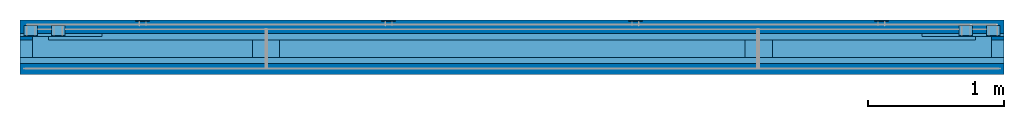
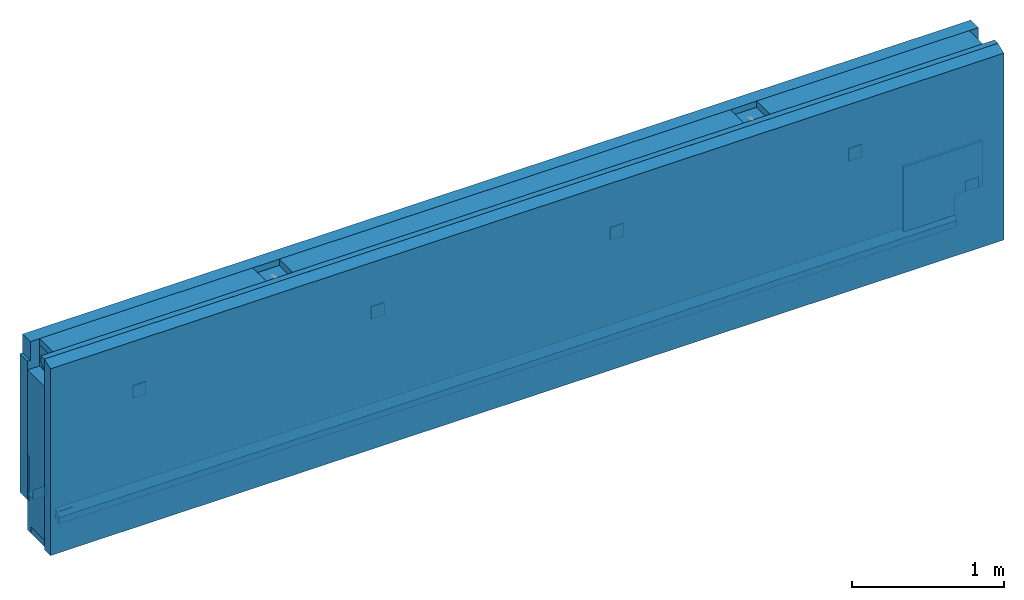
# One storey, part 1 of 10: 8 plates, 4 beams, 3 walls, 2 slabs, 12 elements without a shape of their own.
"""IFC2X3 building model written with IfcOpenShell, lengths in millimetres."""

from ifc_helpers import new_model, si_unit, frame, frame_2d, origin_with_axes, origin_2d_with_axis, place, context, subcontext, project, spatial, polyline, rectangle, outline, extrude, boolean, material, type_object, element, aggregate, save


model = new_model("IFC2X3")

# Units and contexts
model_context = context("Model", 3, precision=1e-05, world=origin_with_axes())
body_context = subcontext(model_context, "Body", "Model", "MODEL_VIEW")
ifc_project = project(units=[si_unit("LENGTHUNIT", "METRE", prefix="MILLI"), si_unit("AREAUNIT", "SQUARE_METRE"), si_unit("VOLUMEUNIT", "CUBIC_METRE"), si_unit("MASSUNIT", "GRAM", prefix="KILO"), si_unit("TIMEUNIT", "SECOND"), si_unit("PLANEANGLEUNIT", "RADIAN"), si_unit("SOLIDANGLEUNIT", "STERADIAN"), si_unit("THERMODYNAMICTEMPERATUREUNIT", "DEGREE_CELSIUS"), si_unit("LUMINOUSINTENSITYUNIT", "LUMEN")], contexts=[model_context])

# Site, building, storey
site_placement = place(None, origin_with_axes())
site = spatial("IfcSite", under=ifc_project, at=site_placement, CompositionType="ELEMENT")
building_placement = place(site_placement, origin_with_axes())
building = spatial("IfcBuilding", under=site, at=building_placement, Name="Undefined", CompositionType="ELEMENT")
storey_placement = place(building_placement, origin_with_axes())
storey = spatial("IfcBuildingStorey", under=building, at=storey_placement, Name="Undefined", CompositionType="ELEMENT", Elevation=0.0)

# Assembly, beams
assembly_1_placement = place(storey_placement, origin_with_axes())
assembly_1 = element("IfcElementAssembly", 1, at=assembly_1_placement, inside=storey, AssemblyPlace="NOTDEFINED", PredefinedType="REINFORCEMENT_UNIT")
ifc_material_1 = material(Name="CONCRETE/C30/37")
beam_type_1 = type_object("IfcBeamType", Name="600X600", PredefinedType="NOTDEFINED")
beam_1_placement = place(assembly_1_placement, frame((14999.9998000424, -202.500205694594, 672.500000000001), z_axis=(0.0, 0.0, 1.0), x_axis=(-7.84935082265784e-18, -1.0, -8.08224170819634e-13)))
beam_1 = element("IfcBeam", 2, at=beam_1_placement, type_object=beam_type_1, material=ifc_material_1, ObjectType="600X600", context=body_context, shape_type="CSG", body=[
    boolean("DIFFERENCE", extrude(rectangle(XDim=600.0, YDim=600.0, at=origin_2d_with_axis()), frame((20.0, 0.0, 0.0), z_axis=(-1.0, -1.7999998817686e-08, 3.23999979946689e-16), x_axis=(-7.84935082265784e-18, -1.0, -8.08224170819634e-13)), (0.0, 0.0, 1.0), 20.0), extrude(rectangle(XDim=210.0, YDim=240.0, at=origin_2d_with_axis()), frame((299.999999999992, -194.999999999993, -179.999999999999), z_axis=(-1.0, -1.7999998817686e-08, 3.23999979946689e-16), x_axis=(-7.84935082265784e-18, -1.0, -8.08224170819634e-13)), (0.0, 0.0, 1.0), 500.0)),
])
beam_2_placement = place(assembly_1_placement, frame((21619.9998000424, -202.500205694595, 672.5), z_axis=(0.0, 0.0, 1.0), x_axis=(-7.84935082265784e-18, -1.0, -8.08224170819634e-13)))
beam_2 = element("IfcBeam", 3, at=beam_2_placement, type_object=beam_type_1, material=ifc_material_1, ObjectType="600X600", context=body_context, shape_type="CSG", body=[
    boolean("DIFFERENCE", extrude(rectangle(XDim=600.0, YDim=600.0, at=origin_2d_with_axis()), frame((20.0, 0.0, 0.0), z_axis=(-1.0, -1.7999998817686e-08, 3.23999979946689e-16), x_axis=(-7.84935082265784e-18, -1.0, -8.08224170819634e-13)), (0.0, 0.0, 1.0), 20.0), extrude(rectangle(XDim=210.0, YDim=240.0, at=origin_2d_with_axis()), frame((299.999999999991, 195.0, -179.999999999999), z_axis=(-1.0, -1.7999998817686e-08, 3.23999979946689e-16), x_axis=(-7.84935082265784e-18, -1.0, -8.08224170819634e-13)), (0.0, 0.0, 1.0), 500.0)),
])

# Assembly, beam
assembly_2_placement = place(storey_placement, origin_with_axes())
assembly_2 = element("IfcElementAssembly", 4, at=assembly_2_placement, inside=storey, AssemblyPlace="NOTDEFINED", PredefinedType="NOTDEFINED")
ifc_material_2 = material(Name="TIMBER/C24")
beam_type_2 = type_object("IfcBeamType", Name="50X175", PredefinedType="NOTDEFINED")
beam_3_placement = place(assembly_2_placement, frame((21919.9998033964, -335.000205699542, 397.499999999999), z_axis=(0.0, 0.0, 1.0), x_axis=(-1.0, -1.7999998817686e-08, 3.23999979946689e-16)))
beam_3 = element("IfcBeam", 5, at=beam_3_placement, type_object=beam_type_2, material=ifc_material_2, ObjectType="50X175", context=body_context, shape_type="SweptSolid", body=[
    extrude(rectangle(XDim=175.0, YDim=50.0, at=origin_2d_with_axis()), frame((7219.99979645404, 5.97224385426358e-21, 0.0), z_axis=(-1.0, -1.7999998817686e-08, 3.23999979946689e-16), x_axis=(-7.84935082265784e-18, -1.0, -8.08224170819634e-13)), (0.0, 0.0, 1.0), 7220.0),
])
aggregate(assembly_2, [beam_3])

assembly_3_placement = place(storey_placement, origin_with_axes())
assembly_3 = element("IfcElementAssembly", 6, at=assembly_3_placement, inside=storey, AssemblyPlace="NOTDEFINED", PredefinedType="NOTDEFINED")
beam_4_placement = place(assembly_3_placement, frame((21919.9998007894, -290.000205686386, 1847.5), z_axis=(0.0, 0.0, 1.0), x_axis=(-1.0, -1.7999998817686e-08, 3.23999979946689e-16)))
beam_4 = element("IfcBeam", 7, at=beam_4_placement, type_object=beam_type_2, material=ifc_material_2, ObjectType="50X175", context=body_context, shape_type="CSG", body=[
    boolean("DIFFERENCE", boolean("DIFFERENCE", boolean("DIFFERENCE", boolean("DIFFERENCE", extrude(rectangle(XDim=175.0, YDim=50.0, at=origin_2d_with_axis()), frame((7219.99979645404, 5.97224385426358e-21, 0.0), z_axis=(-1.0, -1.7999998817686e-08, 3.23999979946689e-16), x_axis=(-7.84935082265784e-18, -1.0, -8.08224170819634e-13)), (0.0, 0.0, 1.0), 7220.0), extrude(rectangle(XDim=200.0, YDim=50.0, at=origin_2d_with_axis()), frame((5414.63995375537, 132.499974342812, -4.54747350886464e-13), z_axis=(-7.84935082265784e-18, -1.0, -8.08224170819634e-13), x_axis=(-1.0, -1.7999998817686e-08, 3.23999979946689e-16)), (0.0, 0.0, 1.0), 320.0)), extrude(rectangle(XDim=200.0, YDim=50.0, at=origin_2d_with_axis()), frame((1799.37995375537, 132.499999649632, -4.54747350886464e-13), z_axis=(-7.84935082265784e-18, -1.0, -8.08224170819634e-13), x_axis=(-1.0, -1.7999998817686e-08, 3.23999979946689e-16)), (0.0, 0.0, 1.0), 320.0)), extrude(rectangle(XDim=90.0, YDim=220.0, at=origin_2d_with_axis()), frame((7175.00000188457, 162.49994852021, -84.9999999999991), z_axis=(-7.84935082265784e-18, -1.0, -8.08224170819634e-13), x_axis=(1.0, 0.0, 0.0)), (0.0, 0.0, 1.0), 300.0)), extrude(rectangle(XDim=90.0, YDim=220.0, at=origin_2d_with_axis()), frame((45.0000018845698, 162.49999843021, -84.9999999999991), z_axis=(-7.84935082265784e-18, -1.0, -8.08224170819634e-13), x_axis=(1.0, 0.0, 0.0)), (0.0, 0.0, 1.0), 300.0)),
])
aggregate(assembly_3, [beam_4])

# Assembly, plate
assembly_4_placement = place(storey_placement, origin_with_axes())
assembly_4 = element("IfcElementAssembly", 8, at=assembly_4_placement, inside=storey, Name="Steel Assembly", AssemblyPlace="NOTDEFINED", PredefinedType="RIGID_FRAME")
ifc_material_3 = material(Name="STEEL/Steel_Undefined")
plate_type_1 = type_object("IfcPlateType", Name="PL100X10", PredefinedType="NOTDEFINED")
plate_1_placement = place(assembly_4_placement, frame((17404.9998002224, -112.500206835272, 1072.49943678625), z_axis=(-1.0, -1.7999998817686e-08, 3.23999979946689e-16), x_axis=(0.0, 0.0, 1.0)))
plate_1 = element("IfcPlate", 9, at=plate_1_placement, type_object=plate_type_1, material=ifc_material_3, Name="RT38", ObjectType="PL100X10", context=body_context, shape_type="SweptSolid", body=[
    extrude(outline(polyline([(0.0, 0.0), (100.0, -2.1316282072803e-11), (99.9999999999984, 9.99999999997873), (-1.59161572810262e-12, 10.0), (0.0, 0.0)])), frame((0.0, 1.26163860546922e-22, -50.0), z_axis=(0.0, 0.0, 1.0), x_axis=(1.0, 0.0, 0.0)), (0.0, 0.0, 1.0), 100.0),
])
aggregate(assembly_4, [plate_1])

assembly_5_placement = place(storey_placement, origin_with_axes())
assembly_5 = element("IfcElementAssembly", 10, at=assembly_5_placement, inside=storey, Name="Steel Assembly", AssemblyPlace="NOTDEFINED", PredefinedType="RIGID_FRAME")
plate_2_placement = place(assembly_5_placement, frame((19214.9998002224, -112.500206835272, 1072.49943678625), z_axis=(-1.0, -1.7999998817686e-08, 3.23999979946689e-16), x_axis=(0.0, 0.0, 1.0)))
plate_2 = element("IfcPlate", 11, at=plate_2_placement, type_object=plate_type_1, material=ifc_material_3, Name="RT38", ObjectType="PL100X10", context=body_context, shape_type="SweptSolid", body=[
    extrude(outline(polyline([(0.0, 0.0), (100.0, -2.1316282072803e-11), (99.9999999999984, 9.99999999997873), (-1.59161572810262e-12, 10.0), (0.0, 0.0)])), frame((0.0, 1.26163860546922e-22, -50.0), z_axis=(0.0, 0.0, 1.0), x_axis=(1.0, 0.0, 0.0)), (0.0, 0.0, 1.0), 100.0),
])
aggregate(assembly_5, [plate_2])

assembly_6_placement = place(storey_placement, origin_with_axes())
assembly_6 = element("IfcElementAssembly", 12, at=assembly_6_placement, inside=storey, Name="Steel Assembly", AssemblyPlace="NOTDEFINED", PredefinedType="RIGID_FRAME")
plate_3_placement = place(assembly_6_placement, frame((21019.9998002224, -112.500206835272, 1072.49943678625), z_axis=(-1.0, -1.7999998817686e-08, 3.23999979946689e-16), x_axis=(0.0, 0.0, 1.0)))
plate_3 = element("IfcPlate", 13, at=plate_3_placement, type_object=plate_type_1, material=ifc_material_3, Name="RT38", ObjectType="PL100X10", context=body_context, shape_type="SweptSolid", body=[
    extrude(outline(polyline([(0.0, 0.0), (100.0, -2.1316282072803e-11), (99.9999999999984, 9.99999999997873), (-1.59161572810262e-12, 10.0), (0.0, 0.0)])), frame((0.0, 1.26163860546922e-22, -50.0), z_axis=(0.0, 0.0, 1.0), x_axis=(1.0, 0.0, 0.0)), (0.0, 0.0, 1.0), 100.0),
])
aggregate(assembly_6, [plate_3])

assembly_7_placement = place(storey_placement, origin_with_axes())
assembly_7 = element("IfcElementAssembly", 14, at=assembly_7_placement, inside=storey, Name="Steel Assembly", AssemblyPlace="NOTDEFINED", PredefinedType="RIGID_FRAME")
plate_4_placement = place(assembly_7_placement, frame((15599.9998002224, -112.500206835272, 1072.49943678625), z_axis=(-1.0, -1.7999998817686e-08, 3.23999979946689e-16), x_axis=(0.0, 0.0, 1.0)))
plate_4 = element("IfcPlate", 15, at=plate_4_placement, type_object=plate_type_1, material=ifc_material_3, Name="RT38", ObjectType="PL100X10", context=body_context, shape_type="SweptSolid", body=[
    extrude(outline(polyline([(0.0, 0.0), (100.0, -2.1316282072803e-11), (99.9999999999984, 9.99999999997873), (-1.59161572810262e-12, 10.0), (0.0, 0.0)])), frame((0.0, 1.26163860546922e-22, -50.0), z_axis=(0.0, 0.0, 1.0), x_axis=(1.0, 0.0, 0.0)), (0.0, 0.0, 1.0), 100.0),
])
aggregate(assembly_7, [plate_4])

assembly_8_placement = place(storey_placement, origin_with_axes())
assembly_8 = element("IfcElementAssembly", 16, at=assembly_8_placement, inside=storey, Name="Steel Assembly", AssemblyPlace="NOTDEFINED", PredefinedType="RIGID_FRAME")
plate_type_2 = type_object("IfcPlateType", Name="PL100X80", PredefinedType="NOTDEFINED")
plate_5_placement = place(assembly_8_placement, frame((14780.0001999576, -222.499790525409, 612.499999999998), z_axis=(1.0, 0.0, 0.0), x_axis=(0.0, 1.0, 0.0)))
plate_5 = element("IfcPlate", 17, at=plate_5_placement, type_object=plate_type_2, material=ifc_material_3, Name="RT24", ObjectType="PL100X80", context=body_context, shape_type="SweptSolid", body=[
    extrude(outline(polyline([(-0.000418949182403594, 0.0), (79.9995810508176, 0.0), (79.9995810508176, 6.0), (5.9995810508176, 6.0), (5.9995810508176, 80.0), (-0.000418949182403594, 80.0), (-0.000418949182403594, 0.0)])), frame((0.0, 1.26163860546922e-22, -50.0), z_axis=(0.0, 0.0, 1.0), x_axis=(1.0, 0.0, 0.0)), (0.0, 0.0, 1.0), 100.0),
])
aggregate(assembly_8, [plate_5])

assembly_9_placement = place(storey_placement, origin_with_axes())
assembly_9 = element("IfcElementAssembly", 18, at=assembly_9_placement, inside=storey, Name="Steel Assembly", AssemblyPlace="NOTDEFINED", PredefinedType="RIGID_FRAME")
plate_6_placement = place(assembly_9_placement, frame((14980.0001999576, -222.499790525409, 372.499999999998), z_axis=(1.0, 0.0, 0.0), x_axis=(0.0, 1.0, 0.0)))
plate_6 = element("IfcPlate", 19, at=plate_6_placement, type_object=plate_type_2, material=ifc_material_3, Name="RT24", ObjectType="PL100X80", context=body_context, shape_type="SweptSolid", body=[
    extrude(outline(polyline([(-0.000418949182403594, 0.0), (79.9995810508176, 0.0), (79.9995810508176, 6.0), (5.9995810508176, 6.0), (5.9995810508176, 80.0), (-0.000418949182403594, 80.0), (-0.000418949182403594, 0.0)])), frame((0.0, 1.26163860546922e-22, -50.0), z_axis=(0.0, 0.0, 1.0), x_axis=(1.0, 0.0, 0.0)), (0.0, 0.0, 1.0), 100.0),
])
aggregate(assembly_9, [plate_6])

assembly_10_placement = place(storey_placement, origin_with_axes())
assembly_10 = element("IfcElementAssembly", 20, at=assembly_10_placement, inside=storey, Name="Steel Assembly", AssemblyPlace="NOTDEFINED", PredefinedType="RIGID_FRAME")
plate_7_placement = place(assembly_10_placement, frame((21640.0001999576, -222.499790525409, 372.499999999998), z_axis=(1.0, 0.0, 0.0), x_axis=(0.0, 1.0, 0.0)))
plate_7 = element("IfcPlate", 21, at=plate_7_placement, type_object=plate_type_2, material=ifc_material_3, Name="RT24", ObjectType="PL100X80", context=body_context, shape_type="SweptSolid", body=[
    extrude(outline(polyline([(-0.000418949182403594, 0.0), (79.9995810508176, 0.0), (79.9995810508176, 6.0), (5.9995810508176, 6.0), (5.9995810508176, 80.0), (-0.000418949182403594, 80.0), (-0.000418949182403594, 0.0)])), frame((0.0, 1.26163860546922e-22, -50.0), z_axis=(0.0, 0.0, 1.0), x_axis=(1.0, 0.0, 0.0)), (0.0, 0.0, 1.0), 100.0),
])
aggregate(assembly_10, [plate_7])

assembly_11_placement = place(storey_placement, origin_with_axes())
assembly_11 = element("IfcElementAssembly", 22, at=assembly_11_placement, inside=storey, Name="Steel Assembly", AssemblyPlace="NOTDEFINED", PredefinedType="RIGID_FRAME")
plate_8_placement = place(assembly_11_placement, frame((21840.0001999576, -222.499790525409, 612.499999999998), z_axis=(1.0, 0.0, 0.0), x_axis=(0.0, 1.0, 0.0)))
plate_8 = element("IfcPlate", 23, at=plate_8_placement, type_object=plate_type_2, material=ifc_material_3, Name="RT24", ObjectType="PL100X80", context=body_context, shape_type="SweptSolid", body=[
    extrude(outline(polyline([(-0.000418949182403594, 0.0), (79.9995810508176, 0.0), (79.9995810508176, 6.0), (5.9995810508176, 6.0), (5.9995810508176, 80.0), (-0.000418949182403594, 80.0), (-0.000418949182403594, 0.0)])), frame((0.0, 1.26163860546922e-22, -50.0), z_axis=(0.0, 0.0, 1.0), x_axis=(1.0, 0.0, 0.0)), (0.0, 0.0, 1.0), 100.0),
])
aggregate(assembly_11, [plate_8])

# Slab
ifc_material_4 = material(Name="CONCRETE/C30/37")
slab_type_1 = type_object("IfcSlabType", Name="7220X45", PredefinedType="NOTDEFINED")
slab_1_placement = place(assembly_1_placement, frame((18309.9998013828, -377.500230801622, 1872.5), z_axis=(1.0, 0.0, 0.0), x_axis=(-7.84935082265784e-18, -1.0, -8.08224170819634e-13)))
slab_1 = element("IfcSlab", 24, at=slab_1_placement, type_object=slab_type_1, material=ifc_material_4, ObjectType="7220X45", PredefinedType="FLOOR", context=body_context, shape_type="SweptSolid", body=[
    extrude(outline(polyline([(0.0, 0.0), (45.0000001549068, 0.0), (45.0000001549068, 100.0), (1.54906786065112e-07, 50.0), (0.0, 0.0)])), frame((0.0, 0.0, -3610.0), z_axis=(0.0, 0.0, 1.0), x_axis=(1.0, 0.0, 0.0)), (0.0, 0.0, 1.0), 7220.0),
])

slab_type_2 = type_object("IfcSlabType", Name="6800X45", PredefinedType="NOTDEFINED")
slab_2_placement = place(assembly_1_placement, frame((18309.999802788, -247.500135934181, 372.499999999999), z_axis=(1.0, 0.0, 0.0), x_axis=(0.0, 1.0, 0.0)))
slab_2 = element("IfcSlab", 25, at=slab_2_placement, type_object=slab_type_2, material=ifc_material_1, ObjectType="6800X45", PredefinedType="FLOOR", context=body_context, shape_type="SweptSolid", body=[
    extrude(outline(polyline([(0.0, 0.0), (45.0000001549068, 0.0), (45.0000001549068, 100.0), (1.54906786065112e-07, 50.0), (0.0, 0.0)])), frame((0.0, -5.6843418860808e-14, -3400.0), z_axis=(0.0, 0.0, 1.0), x_axis=(1.0, 0.0, 0.0)), (0.0, 0.0, 1.0), 6800.0),
])

# Assembly, wall
assembly_12_placement = place(storey_placement, origin_with_axes())
assembly_12 = element("IfcElementAssembly", 26, at=assembly_12_placement, inside=storey, Name="Steel Assembly", AssemblyPlace="NOTDEFINED", PredefinedType="NOTDEFINED")
ifc_material_5 = material(Name="COS5ggt")
wall_type_1 = type_object("IfcWallType", Name="1500X220", PredefinedType="NOTDEFINED")
wall_1_placement = place(assembly_12_placement, frame((21919.9998011901, -312.500205694594, 397.5), z_axis=(0.0, 0.0, 1.0), x_axis=(-1.0, -1.7999998817686e-08, 3.23999979946689e-16)))
wall_1 = element("IfcWall", 27, at=wall_1_placement, type_object=wall_type_1, material=ifc_material_5, ObjectType="1500X220", context=body_context, shape_type="CSG", body=[
    boolean("DIFFERENCE", boolean("DIFFERENCE", boolean("DIFFERENCE", boolean("DIFFERENCE", boolean("DIFFERENCE", boolean("DIFFERENCE", extrude(rectangle(XDim=7219.99979729039, YDim=220.0, at=frame_2d((0.0, 3609.9998986452), x_axis=(0.0, -1.0))), frame((0.0, 0.0, -25.0), z_axis=(0.0, 0.0, 1.0), x_axis=(-7.84935082265784e-18, -1.0, -8.08224170819634e-13)), (0.0, 0.0, 1.0), 1500.0), extrude(rectangle(XDim=90.0, YDim=220.0, at=origin_2d_with_axis()), frame((7175.00000212772, 139.999948512001, 1365.0), z_axis=(-7.84935082265784e-18, -1.0, -8.08224170819634e-13), x_axis=(1.0, 0.0, 0.0)), (0.0, 0.0, 1.0), 300.0)), extrude(rectangle(XDim=90.0, YDim=220.0, at=origin_2d_with_axis()), frame((45.000002127725, 139.999998422002, 1365.0), z_axis=(-7.84935082265784e-18, -1.0, -8.08224170819634e-13), x_axis=(1.0, 0.0, 0.0)), (0.0, 0.0, 1.0), 300.0)), extrude(outline(polyline([(0.0, 0.0), (45.0000001549068, 0.0), (45.0000001549068, 100.0), (1.54906786065112e-07, 50.0), (0.0, 0.0)])), frame((7009.99999794708, -65.0000474303088, -25.0000000000009), z_axis=(-1.0, -1.7999998817686e-08, 3.23999979946689e-16), x_axis=(-7.84935082265784e-18, -1.0, -8.08224170819634e-13)), (0.0, 0.0, 1.0), 6800.0)), extrude(rectangle(XDim=175.0, YDim=50.0, at=origin_2d_with_axis()), frame((7219.9997944052, 22.5000000049478, -9.09494701772928e-13), z_axis=(-1.0, -1.7999998817686e-08, 3.23999979946689e-16), x_axis=(-7.84935082265784e-18, -1.0, -8.08224170819634e-13)), (0.0, 0.0, 1.0), 7220.0)), extrude(rectangle(XDim=175.0, YDim=50.0, at=origin_2d_with_axis()), frame((7219.99979655595, -22.500001262988, 1450.0), z_axis=(-1.0, -1.7999998817686e-08, 3.23999979946689e-16), x_axis=(-7.84935082265784e-18, -1.0, -8.08224170819634e-13)), (0.0, 0.0, 1.0), 7220.0)), extrude(outline(polyline([(0.0, 0.0), (45.0000001549068, 0.0), (45.0000001549068, 100.0), (1.54906786065112e-07, 50.0), (0.0, 0.0)])), frame((7219.99999655965, 65.0000781577995, 1475.0), z_axis=(-1.0, -1.7999998817686e-08, 3.23999979946689e-16), x_axis=(0.0, 1.0, 0.0)), (0.0, 0.0, 1.0), 7220.0)),
])
aggregate(assembly_12, [wall_1])

# Wall
wall_type_2 = type_object("IfcWallType", Name="1525X80", PredefinedType="NOTDEFINED")
wall_2_placement = place(assembly_1_placement, frame((21919.9998019722, -462.500205694594, 347.5), z_axis=(0.0, 0.0, 1.0), x_axis=(-1.0, -1.7999998817686e-08, 3.23999979946689e-16)))
wall_2 = element("IfcWall", 28, at=wall_2_placement, type_object=wall_type_2, material=ifc_material_4, ObjectType="1525X80", context=body_context, shape_type="CSG", body=[
    boolean("DIFFERENCE", extrude(rectangle(XDim=7219.99979483744, YDim=80.0, at=frame_2d((0.0, 3609.9998986452), x_axis=(0.0, -1.0))), frame((0.0, 0.0, 0.0), z_axis=(0.0, 0.0, 1.0), x_axis=(-7.84935082265784e-18, -1.0, -8.08224170819634e-13)), (0.0, 0.0, 1.0), 1525.0), extrude(outline(polyline([(0.0, 0.0), (79.999999842608, 0.0), (-1.57392037181125e-07, 30.0), (0.0, 0.0)])), frame((-3.63797880709171e-12, 40.0000001487744, 1525.0), z_axis=(1.0, 0.0, 0.0), x_axis=(-7.84935082265784e-18, -1.0, -8.08224170819634e-13)), (0.0, 0.0, 1.0), 7220.0)),
])

wall_type_3 = type_object("IfcWallType", Name="1500X100", PredefinedType="NOTDEFINED")
wall_3_placement = place(assembly_1_placement, frame((21919.9998002971, -152.500205694594, 372.5), z_axis=(0.0, 0.0, 1.0), x_axis=(-1.0, -1.7999998817686e-08, 3.23999979946689e-16)))
wall_3 = element("IfcWall", 29, at=wall_3_placement, type_object=wall_type_3, material=ifc_material_1, ObjectType="1500X100", context=body_context, shape_type="CSG", body=[
    boolean("DIFFERENCE", boolean("DIFFERENCE", boolean("DIFFERENCE", boolean("DIFFERENCE", extrude(rectangle(XDim=7219.99979935469, YDim=100.0, at=frame_2d((0.0, 3609.9998986452), x_axis=(0.0, -1.0))), frame((0.0, 0.0, 0.0), z_axis=(0.0, 0.0, 1.0), x_axis=(-7.84935082265784e-18, -1.0, -8.08224170819634e-13)), (0.0, 0.0, 1.0), 1500.0), extrude(rectangle(XDim=20.0, YDim=150.0, at=origin_2d_with_axis()), frame((7210.00000130474, 149.999948267002, 1425.0), z_axis=(-7.84935082265784e-18, -1.0, -8.08224170819634e-13), x_axis=(1.0, 0.0, 0.0)), (0.0, 0.0, 1.0), 300.0)), extrude(rectangle(XDim=20.0, YDim=150.0, at=origin_2d_with_axis()), frame((10.0000013047451, 149.999998667002, 1425.0), z_axis=(-7.84935082265784e-18, -1.0, -8.08224170819634e-13), x_axis=(1.0, 0.0, 0.0)), (0.0, 0.0, 1.0), 300.0)), extrude(rectangle(XDim=210.0, YDim=240.0, at=origin_2d_with_axis()), frame((7115.00000270475, 349.999950194992, 120.000000000002), z_axis=(-7.84935082265784e-18, -1.0, -8.08224170819634e-13), x_axis=(1.0, 0.0, 0.0)), (0.0, 0.0, 1.0), 500.0)), extrude(rectangle(XDim=210.0, YDim=240.0, at=origin_2d_with_axis()), frame((105.000002704749, 349.999999264992, 120.000000000001), z_axis=(-7.84935082265784e-18, -1.0, -8.08224170819634e-13), x_axis=(1.0, 0.0, 0.0)), (0.0, 0.0, 1.0), 500.0)),
])

aggregate(assembly_1, [beam_1, beam_2, slab_1, slab_2, wall_2, wall_3])

save(model, "model.ifc")
